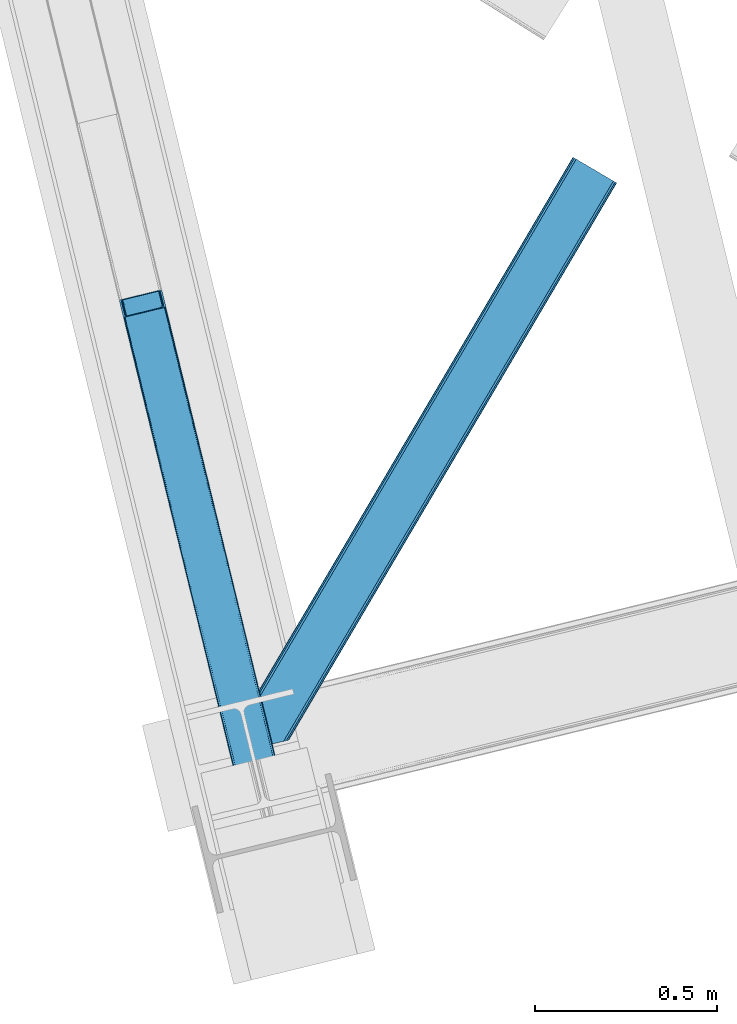
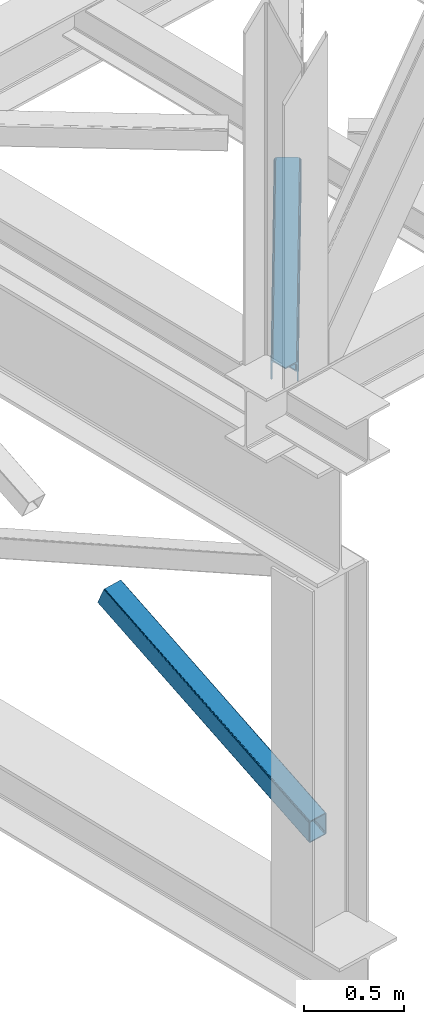
# One storey, part 23 of 92: 2 members.
"""IFC4 building model written with IfcOpenShell, lengths in millimetres."""

from ifc_helpers import new_model, entity, si_unit, converted_unit, derived_unit, direction, frame, origin, place, context, subcontext, project, spatial, triangles, type_object, element, save


model = new_model("IFC4")

# Units and contexts
model_context = context("Model", 3, precision=0.01, world=origin(), true_north=direction((6.12303176911189e-17, 1.0)))
plan_context = context("Plan", 3, precision=0.01, world=origin(), true_north=direction((6.12303176911189e-17, 1.0)))
body_context = subcontext(model_context, "Body", "Model", "MODEL_VIEW")
ifc_project = project(units=[si_unit("LENGTHUNIT", "METRE", prefix="MILLI"), si_unit("AREAUNIT", "SQUARE_METRE"), si_unit("VOLUMEUNIT", "CUBIC_METRE"), converted_unit("PLANEANGLEUNIT", "DEGREE", entity("IfcRatioMeasure", 0.0174532925199433), si_unit("PLANEANGLEUNIT", "RADIAN"), dimensions=[0, 0, 0, 0, 0, 0, 0]), si_unit("MASSUNIT", "GRAM", prefix="KILO"), derived_unit("MASSDENSITYUNIT", [(si_unit("MASSUNIT", "GRAM", prefix="KILO"), 1), (si_unit("LENGTHUNIT", "METRE"), -3)]), derived_unit("MOMENTOFINERTIAUNIT", [(si_unit("LENGTHUNIT", "METRE"), 4)]), si_unit("TIMEUNIT", "SECOND"), si_unit("FREQUENCYUNIT", "HERTZ"), si_unit("THERMODYNAMICTEMPERATUREUNIT", "DEGREE_CELSIUS"), derived_unit("THERMALTRANSMITTANCEUNIT", [(si_unit("MASSUNIT", "GRAM", prefix="KILO"), 1), (si_unit("THERMODYNAMICTEMPERATUREUNIT", "KELVIN"), -1), (si_unit("TIMEUNIT", "SECOND"), -3)]), derived_unit("VOLUMETRICFLOWRATEUNIT", [(si_unit("LENGTHUNIT", "METRE"), 3), (si_unit("TIMEUNIT", "SECOND"), -1)]), derived_unit("MASSFLOWRATEUNIT", [(si_unit("MASSUNIT", "GRAM", prefix="KILO"), 1), (si_unit("TIMEUNIT", "SECOND"), -1)]), derived_unit("ROTATIONALFREQUENCYUNIT", [(si_unit("TIMEUNIT", "SECOND"), -1)]), si_unit("ELECTRICCURRENTUNIT", "AMPERE"), si_unit("ELECTRICVOLTAGEUNIT", "VOLT"), si_unit("POWERUNIT", "WATT"), si_unit("FORCEUNIT", "NEWTON", prefix="KILO"), si_unit("ILLUMINANCEUNIT", "LUX"), si_unit("LUMINOUSFLUXUNIT", "LUMEN"), si_unit("LUMINOUSINTENSITYUNIT", "CANDELA"), derived_unit("USERDEFINED", [(si_unit("MASSUNIT", "GRAM", prefix="KILO"), -1), (si_unit("LENGTHUNIT", "METRE"), -2), (si_unit("TIMEUNIT", "SECOND"), 3), (si_unit("LUMINOUSFLUXUNIT", "LUMEN"), 1)]), derived_unit("LINEARVELOCITYUNIT", [(si_unit("LENGTHUNIT", "METRE"), 1), (si_unit("TIMEUNIT", "SECOND"), -1)]), si_unit("PRESSUREUNIT", "PASCAL"), derived_unit("USERDEFINED", [(si_unit("LENGTHUNIT", "METRE"), -2), (si_unit("MASSUNIT", "GRAM", prefix="KILO"), 1), (si_unit("TIMEUNIT", "SECOND"), -2)]), derived_unit("LINEARFORCEUNIT", [(si_unit("MASSUNIT", "GRAM", prefix="KILO"), 1), (si_unit("LENGTHUNIT", "METRE"), 1), (si_unit("TIMEUNIT", "SECOND"), -2), (si_unit("LENGTHUNIT", "METRE"), -1)]), derived_unit("PLANARFORCEUNIT", [(si_unit("MASSUNIT", "GRAM", prefix="KILO"), 1), (si_unit("LENGTHUNIT", "METRE"), 1), (si_unit("TIMEUNIT", "SECOND"), -2), (si_unit("LENGTHUNIT", "METRE"), -2)])], contexts=[model_context, plan_context])

# Site, building, storey
site_placement = place(None, origin())
site = spatial("IfcSite", under=ifc_project, at=site_placement, CompositionType="ELEMENT")
building_placement = place(site_placement, origin())
building = spatial("IfcBuilding", under=site, at=building_placement, CompositionType="ELEMENT")
storey_placement = place(building_placement, frame((0.0, 0.0, 15900.0)))
storey = spatial("IfcBuildingStorey", under=building, at=storey_placement, Name="05", CompositionType="ELEMENT", Elevation=15900.0)

# Members
member_type_1 = type_object("IfcMemberType", PredefinedType="BRACE")
member_1_placement = place(storey_placement, frame((-60640.96, 2666.96, 911.28)))
element("IfcMember", 1, at=member_1_placement, inside=storey, type_object=member_type_1, ObjectType="Steel Vertical Brace", PredefinedType="BRACE", context=body_context, shape_type="Tessellation", body=[
    triangles([(109.100317382814, 1516.67748184204, 692.224026489257), (472.282800292975, 26.7614479064941, 0.0), (6.11590576171875, 1491.57378158569, 692.224026489257), (369.298388671879, 1.65774765014658, 0.0), (115.806884765625, 1516.48156356812, 696.163320922849), (116.583581542975, 1515.53714447022, 698.605032348631), (479.087036132813, 28.4191955566407, 7.68092651366896), (114.109313964844, 1517.03007659912, 694.092517089841), (478.087097167969, 28.1761871337894, 4.96481323242188), (111.755969238286, 1517.09867706299, 692.710043334959), (477.091809082034, 27.9334693908695, 2.24986267089844), (474.687304687504, 27.3474586486818, 1.12551269531104), (126.913183593751, 1473.16763763428, 795.217739868163), (479.087036132813, 28.4191955566407, 123.979641723632), (123.345959472659, 1469.55913696289, 801.112728881835), (120.792626953131, 1468.71180496216, 801.59758300781), (472.282800292975, 26.7614479064941, 131.659405517577), (125.40164794922, 1470.70354385376, 799.729092407226), (474.687304687504, 27.3474586486818, 130.53505554199), (126.657385253908, 1471.97061767578, 797.659451293945), (477.091809082034, 27.9334693908695, 129.409542846679), (478.087097167969, 28.1761871337894, 126.694592285156), (17.8082153320356, 1443.60810470581, 801.59758300781), (369.298388671879, 1.65774765014658, 131.659405517577), (10.324951171875, 1444.74844207764, 795.217739868163), (362.498803710943, 0.0, 123.979641723632), (363.494091796878, 0.242717742919922, 126.694592285156), (11.1062988281265, 1443.8037322998, 797.659451293945), (364.489379882813, 0.485435485839844, 129.409542846679), (12.7992187500058, 1443.25550994873, 799.729092407226), (366.89388427735, 1.07173690795935, 130.53505554199), (15.152563476564, 1443.18661880493, 801.112728881835), (0.0, 1487.11794891357, 698.605032348631), (362.498803710943, 0.0, 7.68092651366896), (366.89388427735, 1.07173690795935, 1.12551269531104), (3.56722412109957, 1490.72644958496, 692.710043334959), (364.489379882813, 0.485435485839844, 2.24986267089844), (1.50688476562937, 1489.58204269409, 694.092517089841), (363.494091796878, 0.242717742919922, 4.96481323242188), (0.25579833984375, 1488.31496887207, 696.163320922849), (112.2117553711, 1512.35448989868, 703.161730957028), (111.43505859375, 1513.29890899658, 700.720019531247), (109.737487792969, 1513.84742202759, 698.650378417966), (104.728491210939, 1513.49453659058, 696.781887817382), (107.384143066411, 1513.91602249146, 697.266741943356), (120.057788085942, 1471.51802902222, 795.172393798828), (121.569323730473, 1473.98212280273, 790.661041259766), (121.30887451172, 1472.78510284424, 793.102752685547), (117.997448730472, 1470.37362213135, 796.55486755371), (115.448767089845, 1469.52599945068, 797.040884399412), (6.85074462890771, 1488.76755752563, 698.650378417966), (5.59965820312937, 1487.50048370361, 700.720019531247), (11.4597656250044, 1490.75929641724, 696.781887817382), (8.91108398437791, 1489.9119644165, 697.266741943356), (5.34385986328562, 1486.30346374512, 703.161730957028), (17.1710449218808, 1446.43816452026, 795.172393798828), (19.524389648439, 1446.3695640564, 796.55486755371), (15.4734741210996, 1446.98667755127, 793.102752685547), (22.1800415039106, 1446.79075927734, 797.040884399412), (14.69677734375, 1447.93109664917, 790.661041259766), (371.754052734381, 2.25567626953125, 125.048181152342), (374.158557128911, 2.84197769165075, 126.173693847653), (369.349548339844, 1.66966552734402, 123.923831176755), (367.354321289065, 1.18423004150418, 118.492767333984), (368.354260253909, 1.4269477844241, 121.208880615231), (472.236291503912, 26.7495300292971, 123.923831176755), (467.427282714845, 25.5772178649904, 126.173693847653), (469.831787109375, 26.1632286071781, 125.048181152342), (473.231579589847, 26.9922477722171, 121.208880615231), (474.226867675781, 27.234965515137, 118.492767333984), (369.349548339844, 1.66966552734402, 7.73557434081886), (371.754052734381, 2.25567626953125, 6.61122436523146), (367.354321289065, 1.18423004150418, 13.166638183593), (368.354260253909, 1.4269477844241, 10.4505249023423), (374.158557128911, 2.84197769165075, 5.48571166992042), (472.236291503912, 26.7495300292971, 7.73557434081886), (473.231579589847, 26.9922477722171, 10.4505249023423), (469.831787109375, 26.1632286071781, 6.61122436523146), (474.226867675781, 27.234965515137, 13.166638183593), (467.427282714845, 25.5772178649904, 5.48571166992042)], [[1, 2, 3], [4, 3, 2], [5, 6, 7], [8, 5, 9], [10, 8, 11], [1, 10, 12], [12, 2, 1], [11, 12, 10], [9, 11, 8], [7, 9, 5], [6, 13, 14], [14, 7, 6], [15, 16, 17], [18, 15, 19], [20, 18, 21], [13, 20, 22], [22, 14, 13], [21, 22, 20], [19, 21, 18], [17, 19, 15], [17, 16, 23], [23, 24, 17], [25, 26, 27], [28, 27, 29], [30, 29, 31], [32, 31, 24], [24, 23, 32], [31, 32, 30], [29, 30, 28], [27, 28, 25], [25, 33, 26], [34, 26, 33], [3, 4, 35], [36, 35, 37], [38, 37, 39], [40, 39, 34], [34, 33, 40], [39, 40, 38], [37, 38, 36], [35, 36, 3], [41, 6, 42], [43, 5, 8], [8, 10, 43], [6, 41, 13], [6, 5, 43], [43, 42, 6], [44, 1, 3], [1, 45, 43], [44, 45, 1], [1, 43, 10], [18, 46, 15], [47, 13, 41], [46, 20, 13], [48, 13, 47], [20, 46, 18], [46, 16, 15], [13, 48, 46], [46, 49, 16], [16, 50, 23], [50, 16, 49], [51, 33, 52], [3, 53, 44], [54, 3, 51], [3, 54, 53], [51, 3, 36], [55, 52, 33], [36, 38, 51], [40, 51, 38], [55, 33, 25], [40, 33, 51], [56, 32, 23], [57, 56, 23], [58, 25, 56], [59, 23, 50], [23, 59, 57], [30, 32, 56], [25, 60, 55], [28, 56, 25], [60, 25, 58], [56, 28, 30], [61, 62, 24], [27, 63, 31], [27, 31, 29], [24, 62, 17], [24, 31, 61], [63, 61, 31], [64, 26, 34], [26, 65, 63], [64, 65, 26], [26, 63, 27], [19, 66, 22], [67, 17, 62], [68, 19, 17], [68, 17, 67], [22, 21, 19], [66, 14, 22], [19, 68, 66], [66, 69, 14], [14, 70, 7], [70, 14, 69], [71, 35, 72], [34, 73, 64], [74, 34, 71], [34, 74, 73], [71, 34, 39], [72, 4, 75], [71, 39, 35], [35, 39, 37], [75, 4, 2], [35, 4, 72], [76, 9, 7], [77, 76, 7], [78, 12, 76], [79, 7, 70], [7, 79, 77], [12, 9, 76], [2, 80, 75], [12, 78, 2], [80, 2, 78], [11, 9, 12], [80, 44, 75], [53, 75, 44], [44, 80, 78], [45, 78, 76], [43, 76, 77], [42, 77, 79], [79, 41, 42], [77, 42, 43], [76, 43, 45], [78, 45, 44], [47, 41, 70], [79, 70, 41], [47, 70, 69], [48, 69, 66], [46, 66, 68], [49, 68, 67], [67, 50, 49], [68, 49, 46], [66, 46, 48], [69, 48, 47], [50, 67, 59], [62, 59, 67], [57, 59, 62], [56, 57, 61], [58, 56, 63], [60, 58, 65], [65, 64, 60], [63, 65, 58], [61, 63, 56], [62, 61, 57], [55, 60, 64], [64, 73, 55], [52, 55, 73], [51, 52, 74], [54, 51, 71], [53, 54, 72], [72, 75, 53], [71, 72, 54], [74, 71, 51], [73, 74, 52]]),
])
member_type_2 = type_object("IfcMemberType", PredefinedType="BRACE")
member_2_placement = place(storey_placement, frame((-60290.05, 2927.62, 3511.0)))
element("IfcMember", 2, at=member_2_placement, inside=storey, type_object=member_type_2, ObjectType="Steel Horizontal Brace", PredefinedType="BRACE", context=body_context, shape_type="Tessellation", body=[
    triangles([(154.446386718751, 124.708666992187, 0.0), (118.769494628912, 271.071535491943, 0.0), (998.971582031256, 1559.19843292236, 0.0), (908.488732910162, 1612.46872787476, 0.0), (1004.74332275391, 1555.80096588135, 1.33247680664135), (156.720666503912, 115.373480987549, 1.33247680664135), (1009.63139648438, 1552.92061843872, 5.12526855468968), (158.650781250006, 107.459719848633, 5.12526855468968), (1012.90096435547, 1550.99602661133, 10.8028289794929), (159.939074707036, 102.171670532226, 10.8028289794929), (1014.04973144532, 1550.32019577026, 17.5000946044929), (160.39486083985, 100.314807128906, 17.5000946044929), (902.716992187503, 1615.86619491577, 1.33247680664135), (116.495214843751, 280.40643081665, 1.33247680664135), (114.574401855469, 288.275717926025, 5.17061462402489), (897.824267578129, 1618.74683303833, 5.12526855468968), (114.495336914064, 288.596628570557, 5.32641906738354), (894.554699707034, 1620.67142486572, 10.8028289794929), (109.625866699222, 287.408910369873, 10.8028289794929), (893.405932617192, 1621.34696502686, 17.5000946044929), (107.821325683595, 286.969111633301, 17.5000946044929), (113.523303222661, 288.35972442627, 18.5197998046897), (114.495336914064, 288.596628570557, 17.5198608398459), (114.420922851568, 288.578606414795, 17.9023956298843), (114.211633300787, 288.527156066894, 18.2279571533218), (113.895373535161, 288.450416564941, 18.4442230224631), (107.821325683595, 286.969111633301, 18.5197998046897), (115.695263671878, 283.683556365967, 17.5198608398459), (115.625500488284, 283.800409698486, 17.8035644531265), (115.565039062501, 283.740238952636, 17.8570495605491), (115.323193359378, 283.495486450195, 18.0768035888686), (115.067395019534, 283.239106750488, 18.3081848144539), (114.830200195313, 283.003074645996, 18.5197998046897), (0.0, 103.824476623535, 18.5197998046897), (2.73471679687646, 92.5987083435057, 18.5197998046897), (893.405932617192, 1621.34696502686, 122.500662231447), (0.0, 103.824476623535, 122.500662231447), (908.488732910162, 1612.46872787476, 139.999594116212), (902.716992187503, 1615.86619491577, 138.667117309571), (3.66954345703562, 88.7658027648927, 138.667117309571), (5.94382324218896, 79.430616760254, 139.999594116212), (897.824267578129, 1618.74683303833, 134.874325561526), (1.73942871094187, 96.6798545837401, 134.874325561526), (894.554699707034, 1620.67142486572, 129.197927856447), (0.451135253912071, 101.967613220215, 129.197927856447), (899.438122558597, 1617.795728302, 24.4996673583992), (2.37659912109666, 94.0669326782227, 24.4996673583992), (900.586889648439, 1617.11989746094, 17.8035644531265), (903.856457519534, 1615.19530563355, 12.1260040283232), (914.516271972658, 1608.9174911499, 6.99957275390625), (908.749182128908, 1612.31495819092, 8.3320495605476), (118.871813964848, 270.648886871338, 8.3320495605476), (121.146093750001, 261.313991546631, 6.99957275390625), (116.941699218754, 278.562938690186, 12.1260040283232), (152.069787597662, 134.4662109375, 6.99957275390625), (992.939392089844, 1562.74996032715, 6.99957275390625), (156.274182128909, 117.217263793945, 12.1260040283232), (154.344067382815, 125.131024932861, 8.3320495605476), (157.520617675786, 112.096646118164, 17.5198608398459), (160.39486083985, 100.314807128906, 17.5198608398459), (899.438122558597, 1617.795728302, 115.501089477541), (2.37659912109666, 94.0669326782227, 115.501089477541), (900.586889648439, 1617.11989746094, 122.196029663086), (2.82773437500146, 92.2100692749023, 122.196029663086), (903.856457519534, 1615.19530563355, 127.87475280762), (4.12067871094041, 86.9223106384275, 127.87475280762), (908.749182128908, 1612.31495819092, 131.667544555665), (6.046142578125, 79.0082588195801, 131.667544555665), (914.516271972658, 1608.9174911499, 133.000021362306), (8.3250732421875, 69.6733634948728, 133.000021362306), (25.3054321289092, 0.0, 133.000021362306), (25.3054321289092, 0.0, 139.999594116212), (90.3619262695356, 15.8580436706543, 139.999594116212), (998.971582031256, 1559.19843292236, 139.999594116212), (1014.04973144532, 1550.32019577026, 122.500662231447), (1012.90096435547, 1550.99602661133, 129.197927856447), (114.0721069336, 21.6376327514649, 122.500662231447), (112.267565917973, 21.1975433349608, 129.197927856447), (1009.63139648438, 1552.92061843872, 134.874325561526), (107.128344726567, 19.9447128295897, 134.874325561526), (1004.74332275391, 1555.80096588135, 138.667117309571), (99.435791015625, 18.0698272705076, 138.667117309571), (159.664672851563, 99.0785453796384, 18.5197998046897), (114.0721069336, 21.6376327514649, 18.5197998046897), (103.161145019534, 18.9779113769532, 18.5197998046897), (156.929956054693, 110.304313659668, 18.5197998046897), (1008.01754150391, 1553.87143249512, 24.4996673583992), (1006.86877441406, 1554.54726333618, 17.8035644531265), (157.222961425781, 111.200479888916, 18.0198303222678), (1003.59920654297, 1556.47185516357, 12.1260040283232), (998.706481933594, 1559.3522026062, 8.3320495605476), (104.588964843751, 19.325855255127, 24.4996673583992), (1003.59920654297, 1556.47185516357, 127.87475280762), (1008.01754150391, 1553.87143249512, 115.501089477541), (1006.86877441406, 1554.54726333618, 122.196029663086), (992.939392089844, 1562.74996032715, 133.000021362306), (998.706481933594, 1559.3522026062, 131.667544555665), (102.784423828125, 18.8857658386228, 122.196029663086), (80.8787841796875, 13.5462661743163, 133.000021362306), (89.9526489257842, 15.7577590942383, 131.667544555665), (97.6452026367188, 17.6329353332517, 127.87475280762), (104.588964843751, 19.325855255127, 115.501089477541)], [[1, 2, 3], [4, 3, 2], [3, 5, 1], [6, 1, 5], [5, 7, 6], [8, 6, 7], [7, 9, 8], [10, 8, 9], [9, 11, 10], [12, 10, 11], [13, 14, 15], [16, 15, 17], [17, 18, 16], [17, 19, 18], [20, 18, 19], [19, 21, 20], [15, 16, 13], [13, 4, 14], [2, 14, 4], [22, 23, 24], [22, 25, 26], [27, 21, 22], [24, 25, 22], [23, 22, 21], [21, 19, 23], [17, 23, 19], [23, 28, 29], [29, 24, 23], [25, 24, 30], [26, 25, 31], [22, 26, 32], [32, 33, 22], [31, 32, 26], [30, 31, 25], [29, 30, 24], [34, 33, 35], [33, 34, 27], [22, 33, 27], [27, 20, 21], [36, 27, 37], [27, 36, 20], [27, 34, 37], [38, 39, 40], [40, 41, 38], [39, 42, 43], [43, 40, 39], [42, 44, 45], [45, 43, 42], [44, 36, 37], [37, 45, 44], [46, 47, 33], [33, 48, 46], [33, 31, 48], [47, 35, 33], [49, 48, 28], [50, 51, 52], [52, 53, 50], [51, 49, 54], [54, 52, 51], [28, 54, 49], [53, 55, 56], [56, 50, 53], [55, 2, 1], [54, 17, 14], [52, 14, 2], [52, 2, 53], [55, 53, 2], [17, 28, 23], [54, 28, 17], [52, 54, 14], [57, 58, 6], [58, 1, 6], [1, 58, 55], [8, 57, 6], [8, 59, 57], [10, 59, 8], [10, 60, 59], [46, 61, 47], [62, 47, 61], [61, 63, 62], [64, 62, 63], [63, 65, 64], [66, 64, 65], [65, 67, 66], [68, 66, 67], [67, 69, 68], [70, 68, 69], [66, 43, 64], [71, 72, 70], [72, 41, 70], [40, 68, 41], [66, 68, 40], [68, 70, 41], [66, 40, 43], [37, 34, 62], [45, 64, 43], [62, 64, 37], [64, 45, 37], [34, 47, 62], [34, 35, 47], [41, 73, 74], [73, 41, 72], [74, 38, 41], [75, 76, 77], [78, 77, 76], [76, 79, 78], [80, 78, 79], [79, 81, 80], [82, 80, 81], [81, 74, 82], [73, 82, 74], [60, 75, 77], [60, 11, 75], [77, 83, 60], [77, 84, 83], [84, 85, 83], [86, 83, 85], [87, 88, 59], [89, 86, 87], [88, 90, 57], [57, 59, 88], [90, 91, 58], [58, 57, 90], [91, 56, 55], [55, 58, 91], [87, 86, 92], [85, 92, 86], [9, 90, 88], [87, 75, 11], [9, 88, 11], [9, 7, 90], [88, 87, 11], [90, 7, 5], [56, 3, 4], [3, 91, 5], [91, 3, 56], [91, 90, 5], [76, 93, 79], [94, 75, 87], [75, 95, 76], [95, 75, 94], [76, 95, 93], [74, 96, 38], [81, 79, 93], [93, 97, 81], [97, 96, 74], [74, 81, 97], [49, 13, 16], [4, 50, 56], [4, 51, 50], [51, 4, 13], [49, 51, 13], [46, 20, 36], [18, 48, 49], [16, 18, 49], [48, 18, 20], [46, 48, 20], [39, 65, 42], [38, 96, 69], [69, 67, 38], [67, 65, 39], [39, 38, 67], [44, 42, 65], [36, 61, 46], [63, 36, 44], [36, 63, 61], [63, 44, 65], [98, 78, 80], [99, 73, 72], [72, 71, 99], [99, 100, 73], [100, 82, 73], [101, 82, 100], [80, 82, 101], [98, 77, 78], [102, 77, 98], [80, 101, 98], [84, 92, 85], [102, 84, 77], [92, 84, 102], [99, 70, 96], [99, 71, 70], [69, 96, 70], [96, 97, 100], [100, 99, 96], [97, 93, 101], [101, 100, 97], [93, 95, 98], [98, 101, 93], [95, 94, 102], [102, 98, 95], [94, 87, 102], [92, 102, 87]]),
])

save(model, "model.ifc")
